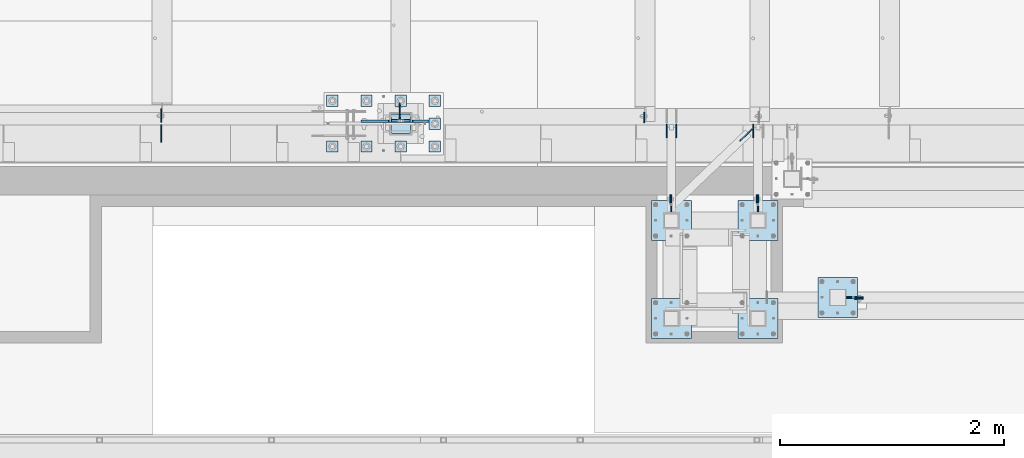
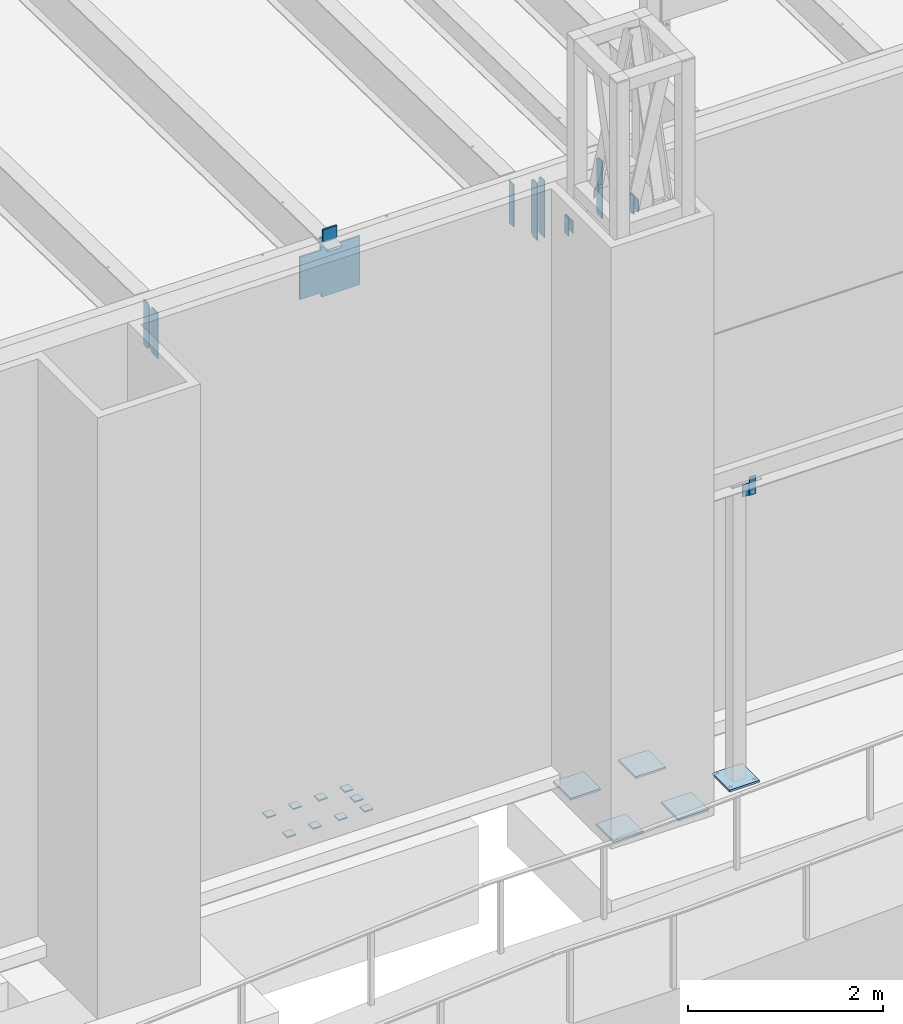
# One storey, part 1429 of 1763: 31 plates, 9 elements without a shape of their own.
"""IFC2X3 building model written with IfcOpenShell, lengths in millimetres."""

from ifc_helpers import new_model, si_unit, frame, origin_with_axes, place, context, subcontext, project, spatial, faceted_brep, material, type_object, element, aggregate, save


model = new_model("IFC2X3")

# Units and contexts
model_context = context("Model", 3, precision=1e-05, world=origin_with_axes())
body_context = subcontext(model_context, "Body", "Model", "MODEL_VIEW")
ifc_project = project(units=[si_unit("LENGTHUNIT", "METRE", prefix="MILLI"), si_unit("AREAUNIT", "SQUARE_METRE"), si_unit("VOLUMEUNIT", "CUBIC_METRE"), si_unit("MASSUNIT", "GRAM", prefix="KILO"), si_unit("TIMEUNIT", "SECOND"), si_unit("PLANEANGLEUNIT", "RADIAN"), si_unit("SOLIDANGLEUNIT", "STERADIAN"), si_unit("THERMODYNAMICTEMPERATUREUNIT", "DEGREE_CELSIUS"), si_unit("LUMINOUSINTENSITYUNIT", "LUMEN")], contexts=[model_context])

# Site, building, storey
site_placement = place(None, origin_with_axes())
site = spatial("IfcSite", under=ifc_project, at=site_placement, CompositionType="ELEMENT")
building_placement = place(site_placement, origin_with_axes())
building = spatial("IfcBuilding", under=site, at=building_placement, Name="Undefined", CompositionType="ELEMENT")
storey_placement = place(building_placement, origin_with_axes())
storey = spatial("IfcBuildingStorey", under=building, at=storey_placement, Name="Undefined", CompositionType="ELEMENT", Elevation=0.0)

# Assembly, plate
assembly_1_placement = place(storey_placement, origin_with_axes())
assembly_1 = element("IfcElementAssembly", 1, at=assembly_1_placement, inside=storey, Name="BEAM", AssemblyPlace="NOTDEFINED", PredefinedType="RIGID_FRAME")
ifc_material_1 = material(Name="STEEL/A36")
plate_type_1 = type_object("IfcPlateType", PredefinedType="NOTDEFINED")
plate_1_placement = place(assembly_1_placement, frame((-68442.9113663098, -15274.9250623919, 8788.4), z_axis=(0.0, 0.0, -1.0), x_axis=(1.0, 0.0, 0.0)))
plate_1 = element("IfcPlate", 2, at=plate_1_placement, type_object=plate_type_1, material=ifc_material_1, Name="PLATE", context=body_context, shape_type="Brep", body=[
    faceted_brep([(0.0, -4.76249999999982, 0.0), (-2.83762346953154e-10, -4.7624999996915, 228.600006103516), (-2.83762346953154e-10, 4.76250000028813, 228.600006103517), (0.0, 4.76249999999982, 0.0), (76.1999969480166, -4.76249999961874, 228.600006103516), (76.1999969480166, 4.76250000036089, 228.600006103517), (76.1999969482931, -4.76249999991705, 0.0), (76.1999969482931, 4.76250000006257, 1.81898940354586e-12)], [[[0, 1, 2, 3]], [[1, 4, 5, 2]], [[4, 6, 7, 5]], [[6, 0, 3, 7]], [[5, 7, 3, 2]], [[6, 4, 1, 0]]]),
])
aggregate(assembly_1, [plate_1])

assembly_2_placement = place(storey_placement, origin_with_axes())
assembly_2 = element("IfcElementAssembly", 3, at=assembly_2_placement, inside=storey, Name="BEAM", AssemblyPlace="NOTDEFINED", PredefinedType="RIGID_FRAME")
plate_2_placement = place(assembly_2_placement, frame((-70087.5618820415, -14427.1992553583, 11863.3875), z_axis=(0.0, 0.0, 1.0), x_axis=(0.0, 1.0, 0.0)))
plate_2 = element("IfcPlate", 4, at=plate_2_placement, type_object=plate_type_1, material=ifc_material_1, Name="PLATE", context=body_context, shape_type="Brep", body=[
    faceted_brep([(0.0, -4.76249999999982, 0.0), (-2.83762346953154e-10, -4.7624999996915, 228.600006103516), (-2.83762346953154e-10, 4.76250000028813, 228.600006103517), (0.0, 4.76249999999982, 0.0), (76.1999969480166, -4.76249999961874, 228.600006103516), (76.1999969480166, 4.76250000036089, 228.600006103517), (76.1999969482931, -4.76249999991705, 0.0), (76.1999969482931, 4.76250000006257, 1.81898940354586e-12)], [[[0, 1, 2, 3]], [[1, 4, 5, 2]], [[4, 6, 7, 5]], [[6, 0, 3, 7]], [[5, 7, 3, 2]], [[6, 4, 1, 0]]]),
])
aggregate(assembly_2, [plate_2])

assembly_3_placement = place(storey_placement, origin_with_axes())
assembly_3 = element("IfcElementAssembly", 5, at=assembly_3_placement, inside=storey, Name="BEAM", AssemblyPlace="NOTDEFINED", PredefinedType="RIGID_FRAME")
plate_3_placement = place(assembly_3_placement, frame((-69316.0366909771, -14427.1992553587, 11863.3875), z_axis=(0.0, 0.0, 1.0), x_axis=(0.0, 1.0, 0.0)))
plate_3 = element("IfcPlate", 6, at=plate_3_placement, type_object=plate_type_1, material=ifc_material_1, Name="PLATE", context=body_context, shape_type="Brep", body=[
    faceted_brep([(0.0, -4.76249999999982, 0.0), (-2.83762346953154e-10, -4.7624999996915, 228.600006103516), (-2.83762346953154e-10, 4.76250000028813, 228.600006103517), (0.0, 4.76249999999982, 0.0), (76.1999969480166, -4.76249999961874, 228.600006103516), (76.1999969480166, 4.76250000036089, 228.600006103517), (76.1999969482931, -4.76249999991705, 0.0), (76.1999969482931, 4.76250000006257, 1.81898940354586e-12)], [[[0, 1, 2, 3]], [[1, 4, 5, 2]], [[4, 6, 7, 5]], [[6, 0, 3, 7]], [[5, 7, 3, 2]], [[6, 4, 1, 0]]]),
])
aggregate(assembly_3, [plate_3])

# Assembly, plates
assembly_4_placement = place(storey_placement, origin_with_axes())
assembly_4 = element("IfcElementAssembly", 7, at=assembly_4_placement, inside=storey, Name="BEAM", AssemblyPlace="NOTDEFINED", PredefinedType="RIGID_FRAME")
plate_type_2 = type_object("IfcPlateType", PredefinedType="NOTDEFINED")
plate_4_placement = place(assembly_4_placement, frame((-70120.89938459, -13843.7935686171, 11466.5125), z_axis=(0.0, 0.0, 1.0), x_axis=(0.0, 1.0, 0.0)))
plate_4 = element("IfcPlate", 8, at=plate_4_placement, type_object=plate_type_2, material=ifc_material_1, Name="PLATE", context=body_context, shape_type="Brep", body=[
    faceted_brep([(0.0, -4.76249999999982, 0.0), (0.0, -4.76249999999709, 717.549987792969), (0.0, 4.76249999999709, 717.549987792969), (0.0, 4.76249999999982, 0.0), (88.9000015258789, -4.76249999999709, 717.549987792969), (88.9000015258789, 4.76249999999709, 717.549987792969), (120.650001525879, -4.76249999999709, 685.799987792969), (120.650001525879, 4.76249999999709, 685.799987792969), (120.650001525879, -4.76249999999709, 31.75), (120.650001525879, 4.76249999999709, 31.75), (88.9000015258789, -4.76249999999709, 0.0), (88.9000015258789, 4.76249999999709, 0.0)], [[[0, 1, 2, 3]], [[1, 4, 5, 2]], [[4, 6, 7, 5]], [[6, 8, 9, 7]], [[8, 10, 11, 9]], [[10, 0, 3, 11]], [[5, 7, 9, 11, 3, 2]], [[10, 8, 6, 4, 1, 0]]]),
])
plate_5_placement = place(assembly_4_placement, frame((-70033.58738459, -13843.7935686171, 11466.5125), z_axis=(0.0, 0.0, 1.0), x_axis=(0.0, 1.0, 0.0)))
plate_5 = element("IfcPlate", 9, at=plate_5_placement, type_object=plate_type_2, material=ifc_material_1, Name="PLATE", context=body_context, shape_type="Brep", body=[
    faceted_brep([(0.0, -4.76249999999982, 0.0), (0.0, -4.76249999999709, 717.549987792969), (0.0, 4.76249999999709, 717.549987792969), (0.0, 4.76249999999982, 0.0), (88.9000015258789, -4.76249999999709, 717.549987792969), (88.9000015258789, 4.76249999999709, 717.549987792969), (120.650001525879, -4.76249999999709, 685.799987792969), (120.650001525879, 4.76249999999709, 685.799987792969), (120.650001525879, -4.76249999999709, 31.75), (120.650001525879, 4.76249999999709, 31.75), (88.9000015258789, -4.76249999999709, 0.0), (88.9000015258789, 4.76249999999709, 0.0)], [[[0, 1, 2, 3]], [[1, 4, 5, 2]], [[4, 6, 7, 5]], [[6, 8, 9, 7]], [[8, 10, 11, 9]], [[10, 0, 3, 11]], [[5, 7, 9, 11, 3, 2]], [[10, 8, 6, 4, 1, 0]]]),
])
plate_6_placement = place(assembly_4_placement, frame((-69349.37388459, -13843.7935686171, 11466.5125), z_axis=(0.0, 0.0, 1.0), x_axis=(0.0, 1.0, 0.0)))
plate_6 = element("IfcPlate", 10, at=plate_6_placement, type_object=plate_type_2, material=ifc_material_1, Name="PLATE", context=body_context, shape_type="Brep", body=[
    faceted_brep([(0.0, -4.76249999999982, 0.0), (0.0, -4.76249999999709, 717.549987792969), (0.0, 4.76249999999709, 717.549987792969), (0.0, 4.76249999999982, 0.0), (88.9000015258789, -4.76249999999709, 717.549987792969), (88.9000015258789, 4.76249999999709, 717.549987792969), (120.650001525879, -4.76249999999709, 685.799987792969), (120.650001525879, 4.76249999999709, 685.799987792969), (120.650001525879, -4.76249999999709, 31.75), (120.650001525879, 4.76249999999709, 31.75), (88.9000015258789, -4.76249999999709, 0.0), (88.9000015258789, 4.76249999999709, 0.0)], [[[0, 1, 2, 3]], [[1, 4, 5, 2]], [[4, 6, 7, 5]], [[6, 8, 9, 7]], [[8, 10, 11, 9]], [[10, 0, 3, 11]], [[5, 7, 9, 11, 3, 2]], [[10, 8, 6, 4, 1, 0]]]),
])

# Assembly, plate
assembly_5_placement = place(storey_placement, origin_with_axes())
assembly_5 = element("IfcElementAssembly", 11, at=assembly_5_placement, inside=storey, Name="BEAM", AssemblyPlace="NOTDEFINED", PredefinedType="RIGID_FRAME")
plate_7_placement = place(assembly_5_placement, frame((-74626.9056307573, -13704.0935686171, 11590.3375), z_axis=(0.0, 0.0, 1.0), x_axis=(0.0, 1.0, 0.0)))
plate_7 = element("IfcPlate", 12, at=plate_7_placement, type_object=plate_type_2, material=ifc_material_1, Name="PLATE", context=body_context, shape_type="Brep", body=[
    faceted_brep([(0.0, -4.76250000000073, 31.75), (0.0, -4.76250000000073, 538.162475585938), (0.0, 4.76250000000073, 538.162475585938), (0.0, 4.76250000000073, 31.75), (31.75, -4.76250000000073, 569.912475585938), (31.75, 4.76250000000073, 569.912475585938), (120.650001525879, -4.76249999999709, 569.912475585938), (120.650001525879, 4.76249999999709, 569.912475585938), (120.650001525879, -4.76249999999709, 0.0), (120.650001525879, 4.76249999999709, 0.0), (31.75, -4.76250000000073, 0.0), (31.75, 4.76250000000073, 0.0)], [[[0, 1, 2, 3]], [[1, 4, 5, 2]], [[4, 6, 7, 5]], [[6, 8, 9, 7]], [[8, 10, 11, 9]], [[10, 0, 3, 11]], [[5, 7, 9, 11, 3, 2]], [[10, 8, 6, 4, 1, 0]]]),
])

assembly_6_placement = place(storey_placement, origin_with_axes())
assembly_6 = element("IfcElementAssembly", 13, at=assembly_6_placement, inside=storey, Name="COLUMN", AssemblyPlace="NOTDEFINED", PredefinedType="RIGID_FRAME")
plate_type_3 = type_object("IfcPlateType", PredefinedType="NOTDEFINED")
plate_8_placement = place(assembly_6_placement, frame((-68366.7113693997, -15265.4000632058, 8559.79999389648), z_axis=(0.0, 0.0, 1.0), x_axis=(-1.0, 0.0, 0.0)))
plate_8 = element("IfcPlate", 14, at=plate_8_placement, type_object=plate_type_3, material=ifc_material_1, Name="PLATE", context=body_context, shape_type="Brep", body=[
    faceted_brep([(0.0, -4.76249999999982, 0.0), (-3.05175672110636e-06, -4.7625000002663, 152.399993896484), (-3.05175490211695e-06, 4.76249999972788, 152.399993896484), (0.0, 4.76249999999982, 0.0), (152.400009155272, -4.76249999975698, 152.399993896484), (152.400009155273, 4.76250000024447, 152.399993896484), (152.400009155272, -4.76249999948777, 5.45696821063757e-12), (152.400009155273, 4.76250000051368, 3.63797880709171e-12)], [[[0, 1, 2, 3]], [[1, 4, 5, 2]], [[4, 6, 7, 5]], [[6, 0, 3, 7]], [[5, 7, 3, 2]], [[6, 4, 1, 0]]]),
])

# Assembly, plates
assembly_7_placement = place(storey_placement, origin_with_axes())
assembly_7 = element("IfcElementAssembly", 15, at=assembly_7_placement, inside=storey, Name="FRAME", AssemblyPlace="NOTDEFINED", PredefinedType="RIGID_FRAME")
plate_9_placement = place(assembly_7_placement, frame((-70078.0368835415, -14350.9992583625, 12091.9875061035), z_axis=(0.0, 0.0, -1.0), x_axis=(0.0, -1.0, 0.0)))
plate_9 = element("IfcPlate", 16, at=plate_9_placement, type_object=plate_type_3, material=ifc_material_1, Name="PLATE", context=body_context, shape_type="Brep", body=[
    faceted_brep([(0.0, -4.76249999999982, 0.0), (-3.05175672110636e-06, -4.7625000002663, 152.399993896484), (-3.05175490211695e-06, 4.76249999972788, 152.399993896484), (0.0, 4.76249999999982, 0.0), (152.400009155272, -4.76249999975698, 152.399993896484), (152.400009155273, 4.76250000024447, 152.399993896484), (152.400009155272, -4.76249999948777, 5.45696821063757e-12), (152.400009155273, 4.76250000051368, 3.63797880709171e-12)], [[[0, 1, 2, 3]], [[1, 4, 5, 2]], [[4, 6, 7, 5]], [[6, 0, 3, 7]], [[5, 7, 3, 2]], [[6, 4, 1, 0]]]),
])
plate_10_placement = place(assembly_7_placement, frame((-69306.5116924771, -14350.9992583629, 12091.9875061035), z_axis=(0.0, 0.0, -1.0), x_axis=(0.0, -1.0, 0.0)))
plate_10 = element("IfcPlate", 17, at=plate_10_placement, type_object=plate_type_3, material=ifc_material_1, Name="PLATE", context=body_context, shape_type="Brep", body=[
    faceted_brep([(0.0, -4.76249999999982, 0.0), (-3.05175672110636e-06, -4.7625000002663, 152.399993896484), (-3.05175490211695e-06, 4.76249999972788, 152.399993896484), (0.0, 4.76249999999982, 0.0), (152.400009155272, -4.76249999975698, 152.399993896484), (152.400009155273, 4.76250000024447, 152.399993896484), (152.400009155272, -4.76249999948777, 5.45696821063757e-12), (152.400009155273, 4.76250000051368, 3.63797880709171e-12)], [[[0, 1, 2, 3]], [[1, 4, 5, 2]], [[4, 6, 7, 5]], [[6, 0, 3, 7]], [[5, 7, 3, 2]], [[6, 4, 1, 0]]]),
])

# Plate
plate_type_4 = type_object("IfcPlateType", PredefinedType="NOTDEFINED")
plate_11_placement = place(assembly_6_placement, frame((-68773.1116892775, -15087.6000613784, 5080.0), z_axis=(1.0, 0.0, 0.0), x_axis=(0.0, -1.0, 0.0)))
plate_11 = element("IfcPlate", 18, at=plate_11_placement, type_object=plate_type_4, material=ifc_material_1, Name="PLATE", context=body_context, shape_type="Brep", body=[
    faceted_brep([(0.0, -12.6999999999971, -1.81898940354586e-12), (0.0, -12.6999999999998, 355.600006103516), (0.0, 12.6999999999998, 355.600006103516), (0.0, 12.6999999999971, -1.81898940354586e-12), (355.600006103516, -12.6999999999998, 355.600006103516), (355.600006103516, 12.6999999999998, 355.600006103516), (355.600006103516, -12.6999999999998, 0.0), (355.600006103516, 12.6999999999998, 0.0)], [[[0, 1, 2, 3]], [[1, 4, 5, 2]], [[4, 6, 7, 5]], [[6, 0, 3, 7]], [[5, 7, 3, 2]], [[6, 4, 1, 0]]]),
])

aggregate(assembly_6, [plate_8, plate_11])

plate_12_placement = place(assembly_7_placement, frame((-69484.3116892775, -14401.7992675181, 5079.99999999999), z_axis=(1.0, 0.0, 0.0), x_axis=(0.0, -1.0, 0.0)))
plate_12 = element("IfcPlate", 19, at=plate_12_placement, type_object=plate_type_4, material=ifc_material_1, Name="PLATE", context=body_context, shape_type="Brep", body=[
    faceted_brep([(0.0, -12.6999999999971, -1.81898940354586e-12), (0.0, -12.6999999999998, 355.600006103516), (0.0, 12.6999999999998, 355.600006103516), (0.0, 12.6999999999971, -1.81898940354586e-12), (355.600006103516, -12.6999999999998, 355.600006103516), (355.600006103516, 12.6999999999998, 355.600006103516), (355.600006103516, -12.6999999999998, 0.0), (355.600006103516, 12.6999999999998, 0.0)], [[[0, 1, 2, 3]], [[1, 4, 5, 2]], [[4, 6, 7, 5]], [[6, 0, 3, 7]], [[5, 7, 3, 2]], [[6, 4, 1, 0]]]),
])

plate_13_placement = place(assembly_7_placement, frame((-70255.83688459, -14401.7992675181, 5079.99999999999), z_axis=(1.0, 0.0, 0.0), x_axis=(0.0, -1.0, 0.0)))
plate_13 = element("IfcPlate", 20, at=plate_13_placement, type_object=plate_type_4, material=ifc_material_1, Name="PLATE", context=body_context, shape_type="Brep", body=[
    faceted_brep([(0.0, -12.6999999999971, -1.81898940354586e-12), (0.0, -12.6999999999998, 355.600006103516), (0.0, 12.6999999999998, 355.600006103516), (0.0, 12.6999999999971, -1.81898940354586e-12), (355.600006103516, -12.6999999999998, 355.600006103516), (355.600006103516, 12.6999999999998, 355.600006103516), (355.600006103516, -12.6999999999998, 0.0), (355.600006103516, 12.6999999999998, 0.0)], [[[0, 1, 2, 3]], [[1, 4, 5, 2]], [[4, 6, 7, 5]], [[6, 0, 3, 7]], [[5, 7, 3, 2]], [[6, 4, 1, 0]]]),
])

plate_14_placement = place(assembly_7_placement, frame((-69484.3116892775, -15274.9242675181, 5079.99999999999), z_axis=(1.0, 0.0, 0.0), x_axis=(0.0, -1.0, 0.0)))
plate_14 = element("IfcPlate", 21, at=plate_14_placement, type_object=plate_type_4, material=ifc_material_1, Name="PLATE", context=body_context, shape_type="Brep", body=[
    faceted_brep([(0.0, -12.6999999999971, -1.81898940354586e-12), (0.0, -12.6999999999998, 355.600006103516), (0.0, 12.6999999999998, 355.600006103516), (0.0, 12.6999999999971, -1.81898940354586e-12), (355.600006103516, -12.6999999999998, 355.600006103516), (355.600006103516, 12.6999999999998, 355.600006103516), (355.600006103516, -12.6999999999998, 0.0), (355.600006103516, 12.6999999999998, 0.0)], [[[0, 1, 2, 3]], [[1, 4, 5, 2]], [[4, 6, 7, 5]], [[6, 0, 3, 7]], [[5, 7, 3, 2]], [[6, 4, 1, 0]]]),
])

plate_15_placement = place(assembly_7_placement, frame((-70255.83688459, -15274.9242675181, 5079.99999999999), z_axis=(1.0, 0.0, 0.0), x_axis=(0.0, -1.0, 0.0)))
plate_15 = element("IfcPlate", 22, at=plate_15_placement, type_object=plate_type_4, material=ifc_material_1, Name="PLATE", context=body_context, shape_type="Brep", body=[
    faceted_brep([(0.0, -12.6999999999971, -1.81898940354586e-12), (0.0, -12.6999999999998, 355.600006103516), (0.0, 12.6999999999998, 355.600006103516), (0.0, 12.6999999999971, -1.81898940354586e-12), (355.600006103516, -12.6999999999998, 355.600006103516), (355.600006103516, 12.6999999999998, 355.600006103516), (355.600006103516, -12.6999999999998, 0.0), (355.600006103516, 12.6999999999998, 0.0)], [[[0, 1, 2, 3]], [[1, 4, 5, 2]], [[4, 6, 7, 5]], [[6, 0, 3, 7]], [[5, 7, 3, 2]], [[6, 4, 1, 0]]]),
])

aggregate(assembly_7, [plate_9, plate_10, plate_12, plate_13, plate_14, plate_15])

# Assembly, plates
assembly_8_placement = place(storey_placement, origin_with_axes())
assembly_8 = element("IfcElementAssembly", 23, at=assembly_8_placement, inside=storey, Name="TEMPLATE", AssemblyPlace="NOTDEFINED", PredefinedType="RIGID_FRAME")
plate_type_5 = type_object("IfcPlateType", PredefinedType="NOTDEFINED")
plate_16_placement = place(assembly_8_placement, frame((-73049.8372736984, -13868.4, 5138.7375), z_axis=(-1.0, 0.0, 0.0), x_axis=(0.0, -1.0, 0.0)))
plate_16 = element("IfcPlate", 24, at=plate_16_placement, type_object=plate_type_5, material=ifc_material_1, Name="WASHER PLATE", context=body_context, shape_type="Brep", body=[
    faceted_brep([(-7.27595761418343e-12, -7.9375, 0.0), (0.0, -7.9375, 101.599998474121), (0.0, 7.9375, 101.599998474121), (-7.27595761418343e-12, 7.9375, 0.0), (101.599998474121, -7.9375, 101.599998474121), (101.599998474121, 7.9375, 101.599998474121), (101.599998474121, -7.9375, 0.0), (101.599998474121, 7.9375, 0.0)], [[[0, 1, 2, 3]], [[1, 4, 5, 2]], [[4, 6, 7, 5]], [[6, 0, 3, 7]], [[5, 7, 3, 2]], [[6, 4, 1, 0]]]),
])
plate_17_placement = place(assembly_8_placement, frame((-72745.0372736984, -13868.4, 5138.7375), z_axis=(-1.0, 0.0, 0.0), x_axis=(0.0, -1.0, 0.0)))
plate_17 = element("IfcPlate", 25, at=plate_17_placement, type_object=plate_type_5, material=ifc_material_1, Name="WASHER PLATE", context=body_context, shape_type="Brep", body=[
    faceted_brep([(-7.27595761418343e-12, -7.9375, 0.0), (0.0, -7.9375, 101.599998474121), (0.0, 7.9375, 101.599998474121), (-7.27595761418343e-12, 7.9375, 0.0), (101.599998474121, -7.9375, 101.599998474121), (101.599998474121, 7.9375, 101.599998474121), (101.599998474121, -7.9375, 0.0), (101.599998474121, 7.9375, 0.0)], [[[0, 1, 2, 3]], [[1, 4, 5, 2]], [[4, 6, 7, 5]], [[6, 0, 3, 7]], [[5, 7, 3, 2]], [[6, 4, 1, 0]]]),
])
plate_18_placement = place(assembly_8_placement, frame((-72440.2372736984, -13868.4, 5138.7375), z_axis=(-1.0, 0.0, 0.0), x_axis=(0.0, -1.0, 0.0)))
plate_18 = element("IfcPlate", 26, at=plate_18_placement, type_object=plate_type_5, material=ifc_material_1, Name="WASHER PLATE", context=body_context, shape_type="Brep", body=[
    faceted_brep([(-7.27595761418343e-12, -7.9375, 0.0), (0.0, -7.9375, 101.599998474121), (0.0, 7.9375, 101.599998474121), (-7.27595761418343e-12, 7.9375, 0.0), (101.599998474121, -7.9375, 101.599998474121), (101.599998474121, 7.9375, 101.599998474121), (101.599998474121, -7.9375, 0.0), (101.599998474121, 7.9375, 0.0)], [[[0, 1, 2, 3]], [[1, 4, 5, 2]], [[4, 6, 7, 5]], [[6, 0, 3, 7]], [[5, 7, 3, 2]], [[6, 4, 1, 0]]]),
])
plate_19_placement = place(assembly_8_placement, frame((-72135.4372736984, -13868.4, 5138.7375), z_axis=(-1.0, 0.0, 0.0), x_axis=(0.0, -1.0, 0.0)))
plate_19 = element("IfcPlate", 27, at=plate_19_placement, type_object=plate_type_5, material=ifc_material_1, Name="WASHER PLATE", context=body_context, shape_type="Brep", body=[
    faceted_brep([(-7.27595761418343e-12, -7.9375, 0.0), (0.0, -7.9375, 101.599998474121), (0.0, 7.9375, 101.599998474121), (-7.27595761418343e-12, 7.9375, 0.0), (101.599998474121, -7.9375, 101.599998474121), (101.599998474121, 7.9375, 101.599998474121), (101.599998474121, -7.9375, 0.0), (101.599998474121, 7.9375, 0.0)], [[[0, 1, 2, 3]], [[1, 4, 5, 2]], [[4, 6, 7, 5]], [[6, 0, 3, 7]], [[5, 7, 3, 2]], [[6, 4, 1, 0]]]),
])
plate_20_placement = place(assembly_8_placement, frame((-72135.4372736984, -13665.2, 5138.7375), z_axis=(-1.0, 0.0, 0.0), x_axis=(0.0, -1.0, 0.0)))
plate_20 = element("IfcPlate", 28, at=plate_20_placement, type_object=plate_type_5, material=ifc_material_1, Name="WASHER PLATE", context=body_context, shape_type="Brep", body=[
    faceted_brep([(-7.27595761418343e-12, -7.9375, 0.0), (0.0, -7.9375, 101.599998474121), (0.0, 7.9375, 101.599998474121), (-7.27595761418343e-12, 7.9375, 0.0), (101.599998474121, -7.9375, 101.599998474121), (101.599998474121, 7.9375, 101.599998474121), (101.599998474121, -7.9375, 0.0), (101.599998474121, 7.9375, 0.0)], [[[0, 1, 2, 3]], [[1, 4, 5, 2]], [[4, 6, 7, 5]], [[6, 0, 3, 7]], [[5, 7, 3, 2]], [[6, 4, 1, 0]]]),
])
plate_21_placement = place(assembly_8_placement, frame((-73049.8372736984, -13462.0, 5138.7375), z_axis=(-1.0, 0.0, 0.0), x_axis=(0.0, -1.0, 0.0)))
plate_21 = element("IfcPlate", 29, at=plate_21_placement, type_object=plate_type_5, material=ifc_material_1, Name="WASHER PLATE", context=body_context, shape_type="Brep", body=[
    faceted_brep([(-7.27595761418343e-12, -7.9375, 0.0), (0.0, -7.9375, 101.599998474121), (0.0, 7.9375, 101.599998474121), (-7.27595761418343e-12, 7.9375, 0.0), (101.599998474121, -7.9375, 101.599998474121), (101.599998474121, 7.9375, 101.599998474121), (101.599998474121, -7.9375, 0.0), (101.599998474121, 7.9375, 0.0)], [[[0, 1, 2, 3]], [[1, 4, 5, 2]], [[4, 6, 7, 5]], [[6, 0, 3, 7]], [[5, 7, 3, 2]], [[6, 4, 1, 0]]]),
])
plate_22_placement = place(assembly_8_placement, frame((-72745.0372736984, -13462.0, 5138.7375), z_axis=(-1.0, 0.0, 0.0), x_axis=(0.0, -1.0, 0.0)))
plate_22 = element("IfcPlate", 30, at=plate_22_placement, type_object=plate_type_5, material=ifc_material_1, Name="WASHER PLATE", context=body_context, shape_type="Brep", body=[
    faceted_brep([(-7.27595761418343e-12, -7.9375, 0.0), (0.0, -7.9375, 101.599998474121), (0.0, 7.9375, 101.599998474121), (-7.27595761418343e-12, 7.9375, 0.0), (101.599998474121, -7.9375, 101.599998474121), (101.599998474121, 7.9375, 101.599998474121), (101.599998474121, -7.9375, 0.0), (101.599998474121, 7.9375, 0.0)], [[[0, 1, 2, 3]], [[1, 4, 5, 2]], [[4, 6, 7, 5]], [[6, 0, 3, 7]], [[5, 7, 3, 2]], [[6, 4, 1, 0]]]),
])
plate_23_placement = place(assembly_8_placement, frame((-72440.2372736984, -13462.0, 5138.7375), z_axis=(-1.0, 0.0, 0.0), x_axis=(0.0, -1.0, 0.0)))
plate_23 = element("IfcPlate", 31, at=plate_23_placement, type_object=plate_type_5, material=ifc_material_1, Name="WASHER PLATE", context=body_context, shape_type="Brep", body=[
    faceted_brep([(-7.27595761418343e-12, -7.9375, 0.0), (0.0, -7.9375, 101.599998474121), (0.0, 7.9375, 101.599998474121), (-7.27595761418343e-12, 7.9375, 0.0), (101.599998474121, -7.9375, 101.599998474121), (101.599998474121, 7.9375, 101.599998474121), (101.599998474121, -7.9375, 0.0), (101.599998474121, 7.9375, 0.0)], [[[0, 1, 2, 3]], [[1, 4, 5, 2]], [[4, 6, 7, 5]], [[6, 0, 3, 7]], [[5, 7, 3, 2]], [[6, 4, 1, 0]]]),
])
plate_24_placement = place(assembly_8_placement, frame((-72135.4372736984, -13462.0, 5138.7375), z_axis=(-1.0, 0.0, 0.0), x_axis=(0.0, -1.0, 0.0)))
plate_24 = element("IfcPlate", 32, at=plate_24_placement, type_object=plate_type_5, material=ifc_material_1, Name="WASHER PLATE", context=body_context, shape_type="Brep", body=[
    faceted_brep([(-7.27595761418343e-12, -7.9375, 0.0), (0.0, -7.9375, 101.599998474121), (0.0, 7.9375, 101.599998474121), (-7.27595761418343e-12, 7.9375, 0.0), (101.599998474121, -7.9375, 101.599998474121), (101.599998474121, 7.9375, 101.599998474121), (101.599998474121, -7.9375, 0.0), (101.599998474121, 7.9375, 0.0)], [[[0, 1, 2, 3]], [[1, 4, 5, 2]], [[4, 6, 7, 5]], [[6, 0, 3, 7]], [[5, 7, 3, 2]], [[6, 4, 1, 0]]]),
])
aggregate(assembly_8, [plate_16, plate_17, plate_18, plate_19, plate_20, plate_21, plate_22, plate_23, plate_24])

# Assembly, plate
assembly_9_placement = place(storey_placement, origin_with_axes())
assembly_9 = element("IfcElementAssembly", 33, at=assembly_9_placement, inside=storey, Name="COLUMN", AssemblyPlace="NOTDEFINED", PredefinedType="RIGID_FRAME")
ifc_material_2 = material(Name="STEEL/A572-50")
plate_type_6 = type_object("IfcPlateType", PredefinedType="NOTDEFINED")
plate_25_placement = place(assembly_9_placement, frame((-72408.4872721725, -13690.5998186171, 12369.7999938965), z_axis=(0.0, 0.0, -1.0), x_axis=(-1.0, 0.0, 0.0)))
plate_25 = element("IfcPlate", 34, at=plate_25_placement, type_object=plate_type_6, material=ifc_material_2, Name="PLATE", context=body_context, shape_type="Brep", body=[
    faceted_brep([(7.27595761418343e-12, 9.52500000000146, 155.574990844727), (-1.45519152283669e-11, 7.27595761418343e-12, 165.099990844727), (165.099990844727, 0.0, 165.099990844727), (165.099990844727, 9.52500000000146, 155.574990844727), (-3.63797880709171e-11, -9.5249999999869, 155.574990844727), (165.099990844727, -9.52500000000146, 155.574990844727), (0.0, 9.52500000000146, 0.0), (0.0, -9.52500000000146, 0.0), (165.099990844727, -9.52500000000146, 0.0), (165.099990844727, 9.52500000000146, 0.0)], [[[0, 1, 2, 3]], [[1, 4, 5, 2]], [[6, 7, 4, 1, 0]], [[5, 8, 9, 3, 2]], [[8, 7, 6, 9]], [[9, 6, 0, 3]], [[7, 8, 5, 4]]]),
])

# Plate
plate_type_7 = type_object("IfcPlateType", PredefinedType="NOTDEFINED")
plate_26_placement = place(assembly_4_placement, frame((-69466.634611975, -13868.9289365965, 11774.4875), z_axis=(0.0, 0.0, 1.0), x_axis=(0.723320631729244, 0.690512319741514, 0.0)))
plate_26 = element("IfcPlate", 35, at=plate_26_placement, type_object=plate_type_7, material=ifc_material_1, Name="PLATE", context=body_context, shape_type="Brep", body=[
    faceted_brep([(0.0, -4.76249999999982, 0.0), (1.45519152283669e-11, -4.76250000000448, 101.60001373291), (0.0, 4.76250000000243, 101.60001373291), (0.0, 4.76249999999982, 0.0), (150.983306885064, -4.76250000033906, 101.60001373291), (150.9833068851, 4.76249999961874, 101.60001373291), (150.983306885064, -4.76250000033906, 0.0), (150.9833068851, 4.76249999961874, 0.0)], [[[0, 1, 2, 3]], [[1, 4, 5, 2]], [[4, 6, 7, 5]], [[6, 0, 3, 7]], [[5, 7, 3, 2]], [[6, 4, 1, 0]]]),
])

plate_type_8 = type_object("IfcPlateType", PredefinedType="NOTDEFINED")
plate_27_placement = place(assembly_9_placement, frame((-72592.6372736984, -13694.5688188612, 12128.5), z_axis=(1.0, 0.0, 0.0), x_axis=(0.0, 0.0, 1.0)))
plate_27 = element("IfcPlate", 36, at=plate_27_placement, type_object=plate_type_8, material=ifc_material_2, Name="PLATE", context=body_context, shape_type="Brep", body=[
    faceted_brep([(12.6999998092651, -9.52499999999964, 0.0), (7.83992029121873, -9.52499999999964, -0.966729922583909), (7.83992029121873, 9.52499999999964, -0.966729922583909), (12.6999998092651, 9.52499999999964, 0.0), (3.71974382306507, -9.52499999999964, -3.71974382306507), (3.71974382306507, 9.52499999999964, -3.71974382306507), (0.966729922587547, -9.52499999999964, -7.83992029122601), (0.966729922587547, 9.52499999999964, -7.83992029122601), (0.0, -9.52499999999964, -12.6999998092651), (3.19665128194256e-12, 9.52499999999854, -12.699999332428), (0.0, -9.52499999999964, -254.0), (0.0, 9.52499999999964, -254.0), (-533.400024414062, -9.52499999999964, -254.0), (-533.400024414062, 9.52499999999964, -254.0), (-533.400024414062, -9.52499999999964, -12.6999998092651), (-533.400024414062, 9.52499999999964, -12.6999998092651), (-534.36675433665, -9.52499999999964, -7.83992029122601), (-534.36675433665, 9.52499999999964, -7.83992029122601), (-537.119768237128, -9.52499999999964, -3.71974382306507), (-537.119768237128, 9.52499999999964, -3.71974382306507), (-541.239944705281, -9.52499999999964, -0.966729922583909), (-541.239944705281, 9.52499999999964, -0.966729922583909), (-546.100024223328, -9.52499999999964, 0.0), (-546.100024223328, 9.52499999999964, 0.0), (-590.549987792969, -9.52499999999964, 0.0), (-590.549987792969, 9.52499999999964, 0.0), (-590.549987792969, -9.52499999999964, 457.200012207031), (-590.549987792969, 9.52499999999964, 457.200012207031), (19.0499992370605, -9.52499999999964, 457.200012207031), (19.0499992370605, 9.52499999999964, 457.200012207031), (19.0499992370605, -9.52499999999964, 215.899996757507), (19.0499992370605, 9.52499999999964, 215.899996757507), (20.0167291596481, -9.52499999999964, 211.039917239468), (20.0167291596481, 9.52499999999964, 211.039917239468), (22.7697430601256, -9.52499999999964, 206.919740771307), (22.7697430601256, 9.52499999999964, 206.919740771307), (26.8899195282793, -9.52499999999964, 204.166726870826), (26.8899195282793, 9.52499999999964, 204.166726870826), (31.7499990463257, -9.52499999999964, 203.199996948242), (31.7499990463257, 9.52499999999964, 203.199996948242), (31.7500000000055, 9.52499999999964, 0.0), (31.7500000000055, -9.52499999999964, 0.0)], [[[0, 1, 2, 3]], [[1, 4, 5, 2]], [[4, 6, 7, 5]], [[6, 8, 9, 7]], [[8, 10, 11, 9]], [[10, 12, 13, 11]], [[12, 14, 15, 13]], [[14, 16, 17, 15]], [[16, 18, 19, 17]], [[18, 20, 21, 19]], [[20, 22, 23, 21]], [[22, 24, 25, 23]], [[24, 26, 27, 25]], [[26, 28, 29, 27]], [[28, 30, 31, 29]], [[30, 32, 33, 31]], [[32, 34, 35, 33]], [[34, 36, 37, 35]], [[37, 36, 38, 39]], [[3, 2, 5, 7, 9, 11, 13, 15, 17, 19, 21, 23, 25, 27, 29, 31, 33, 35, 37, 39, 40]], [[0, 3, 40, 41]], [[36, 34, 32, 30, 28, 26, 24, 22, 20, 18, 16, 14, 12, 10, 8, 6, 4, 1, 0, 41, 38]], [[40, 39, 38, 41]]]),
])

plate_type_9 = type_object("IfcPlateType", PredefinedType="NOTDEFINED")
plate_28_placement = place(assembly_4_placement, frame((-70321.2422736983, -13708.8560686171, 12154.1242990454), z_axis=(0.0, 1.0, 0.0), x_axis=(0.0, 0.0, -1.0)))
plate_28 = element("IfcPlate", 37, at=plate_28_placement, type_object=plate_type_9, material=ifc_material_1, Name="PLATE", context=body_context, shape_type="Brep", body=[
    faceted_brep([(0.0, -4.76249999999982, 0.0), (0.0, -4.76249999999709, 95.25), (0.0, 4.76249999999709, 95.25), (0.0, 4.76249999999982, 0.0), (533.400024414062, -4.76249999999709, 95.25), (533.400024414062, 4.76249999999709, 95.25), (533.400024414062, -4.76250000000073, 0.0), (533.400024414062, 4.76250000000073, 0.0)], [[[0, 1, 2, 3]], [[1, 4, 5, 2]], [[4, 6, 7, 5]], [[6, 0, 3, 7]], [[5, 7, 3, 2]], [[6, 4, 1, 0]]]),
])

aggregate(assembly_4, [plate_26, plate_4, plate_5, plate_6, plate_28])

plate_type_10 = type_object("IfcPlateType", PredefinedType="NOTDEFINED")
plate_29_placement = place(assembly_9_placement, frame((-72403.7247736984, -13628.6875, 12172.95), z_axis=(0.0, -1.0, 0.0), x_axis=(-1.0, 0.0, 0.0)))
plate_29 = element("IfcPlate", 38, at=plate_29_placement, type_object=plate_type_10, material=ifc_material_1, Name="PLATE", context=body_context, shape_type="Brep", body=[
    faceted_brep([(-2.18278728425503e-11, -12.7000000000007, 15.875), (0.0, -12.7000000000007, 158.75), (0.0, 12.7000000000007, 158.75), (-2.18278728425503e-11, 12.7000000000007, 15.875), (1.20841242138704, -12.7000000000007, 164.825099488797), (1.20841242138704, 12.7000000000007, 164.825099488797), (4.6496798486769, -12.7000000000007, 169.975320151338), (4.6496798486769, 12.7000000000007, 169.975320151338), (9.79990051120694, -12.7000000000007, 173.416587578617), (9.79990051120694, 12.7000000000007, 173.416587578617), (15.875, -12.7000000000007, 174.625), (15.875, 12.7000000000007, 174.625), (158.75, -12.7000000000007, 174.625), (158.75, 12.7000000000007, 174.625), (164.825099488793, -12.7000000000007, 173.416587578617), (164.825099488793, 12.7000000000007, 173.416587578617), (169.975320151338, -12.7000000000007, 169.975320151336), (169.975320151338, 12.7000000000007, 169.975320151336), (173.416587578613, -12.7000000000007, 164.825099488797), (173.416587578613, 12.7000000000007, 164.825099488797), (174.625, -12.7000000000007, 158.75), (174.625, 12.7000000000007, 158.75), (174.625, -12.7000000000007, 15.8750000000073), (174.625, 12.7000000000007, 15.8750000000073), (173.416587578613, -12.7000000000007, 9.79990051121058), (173.416587578613, 12.7000000000007, 9.79990051121058), (169.975320151338, -12.7000000000007, 4.64967984866962), (169.975320151338, 12.7000000000007, 4.64967984866962), (164.825099488793, -12.7000000000007, 1.20841242139068), (164.825099488793, 12.7000000000007, 1.20841242139068), (158.75, -12.7000000000007, 7.27595761418343e-12), (158.75, 12.7000000000007, 7.27595761418343e-12), (15.8749999999854, -12.7000000000007, 0.0), (15.8749999999854, 12.7000000000007, 0.0), (9.79990051119239, -12.7000000000007, 1.20841242137976), (9.79990051119239, 12.7000000000007, 1.20841242137976), (4.64967984864779, -12.7000000000007, 4.64967984866234), (4.64967984864779, 12.7000000000007, 4.64967984866234), (1.20841242136521, -12.7000000000007, 9.79990051119967), (1.20841242136521, 12.7000000000007, 9.79990051119967)], [[[0, 1, 2, 3]], [[1, 4, 5, 2]], [[4, 6, 7, 5]], [[6, 8, 9, 7]], [[8, 10, 11, 9]], [[10, 12, 13, 11]], [[12, 14, 15, 13]], [[14, 16, 17, 15]], [[16, 18, 19, 17]], [[18, 20, 21, 19]], [[20, 22, 23, 21]], [[22, 24, 25, 23]], [[24, 26, 27, 25]], [[26, 28, 29, 27]], [[28, 30, 31, 29]], [[30, 32, 33, 31]], [[32, 34, 35, 33]], [[34, 36, 37, 35]], [[36, 38, 39, 37]], [[38, 0, 3, 39]], [[5, 7, 9, 11, 13, 15, 17, 19, 21, 23, 25, 27, 29, 31, 33, 35, 37, 39, 3, 2]], [[38, 36, 34, 32, 30, 28, 26, 24, 22, 20, 18, 16, 14, 12, 10, 8, 6, 4, 1, 0]]]),
])

plate_type_11 = type_object("IfcPlateType", PredefinedType="NOTDEFINED")
plate_30_placement = place(assembly_9_placement, frame((-72500.5622729411, -13601.7, 12160.2416542355), z_axis=(0.0, 0.0, -1.0), x_axis=(0.0, -1.0, 0.0)))
plate_30 = element("IfcPlate", 39, at=plate_30_placement, type_object=plate_type_11, material=ifc_material_1, Name="PLATE", context=body_context, shape_type="Brep", body=[
    faceted_brep([(0.0, -4.76249999999982, 0.0), (-88.9000015258789, -4.76249999999709, 0.0), (-88.9000015258789, 4.76249999999709, 0.0), (0.0, 4.76249999999982, 0.0), (-88.9000015258789, -4.76249999999709, 535.781188964844), (-88.9000015258789, 4.76249999999709, 535.781188964844), (83.3436965942383, -4.76249999999709, 535.781188964844), (83.3436965942383, 4.76249999999709, 535.781188964844), (83.3436965942383, -4.76249999999709, 0.0), (83.3436965942383, 4.76249999999709, 0.0)], [[[0, 1, 2, 3]], [[1, 4, 5, 2]], [[4, 6, 7, 5]], [[6, 8, 9, 7]], [[8, 0, 3, 9]], [[5, 7, 9, 3, 2]], [[8, 6, 4, 1, 0]]]),
])

aggregate(assembly_9, [plate_25, plate_27, plate_29, plate_30])

plate_type_12 = type_object("IfcPlateType", PredefinedType="NOTDEFINED")
plate_31_placement = place(assembly_5_placement, frame((-74626.9056307573, -13727.9060686171, 11588.75), z_axis=(0.0, 0.0, 1.0), x_axis=(0.0, -1.0, 0.0)))
plate_31 = element("IfcPlate", 40, at=plate_31_placement, type_object=plate_type_12, material=ifc_material_1, Name="PLATE", context=body_context, shape_type="Brep", body=[
    faceted_brep([(0.0, -4.76250000000073, 31.75), (0.0, -4.76250000000073, 539.75), (0.0, 4.76250000000073, 539.75), (0.0, 4.76250000000073, 31.75), (31.75, -4.76250000000073, 571.5), (31.75, 4.76250000000073, 571.5), (154.78125, -4.76250000000073, 571.5), (154.78125, 4.76250000000073, 571.5), (154.78125, -4.76250000000073, 0.0), (154.78125, 4.76250000000073, 0.0), (31.75, -4.76250000000073, 0.0), (31.75, 4.76250000000073, 0.0)], [[[0, 1, 2, 3]], [[1, 4, 5, 2]], [[4, 6, 7, 5]], [[6, 8, 9, 7]], [[8, 10, 11, 9]], [[10, 0, 3, 11]], [[5, 7, 9, 11, 3, 2]], [[10, 8, 6, 4, 1, 0]]]),
])

aggregate(assembly_5, [plate_31, plate_7])

save(model, "model.ifc")
